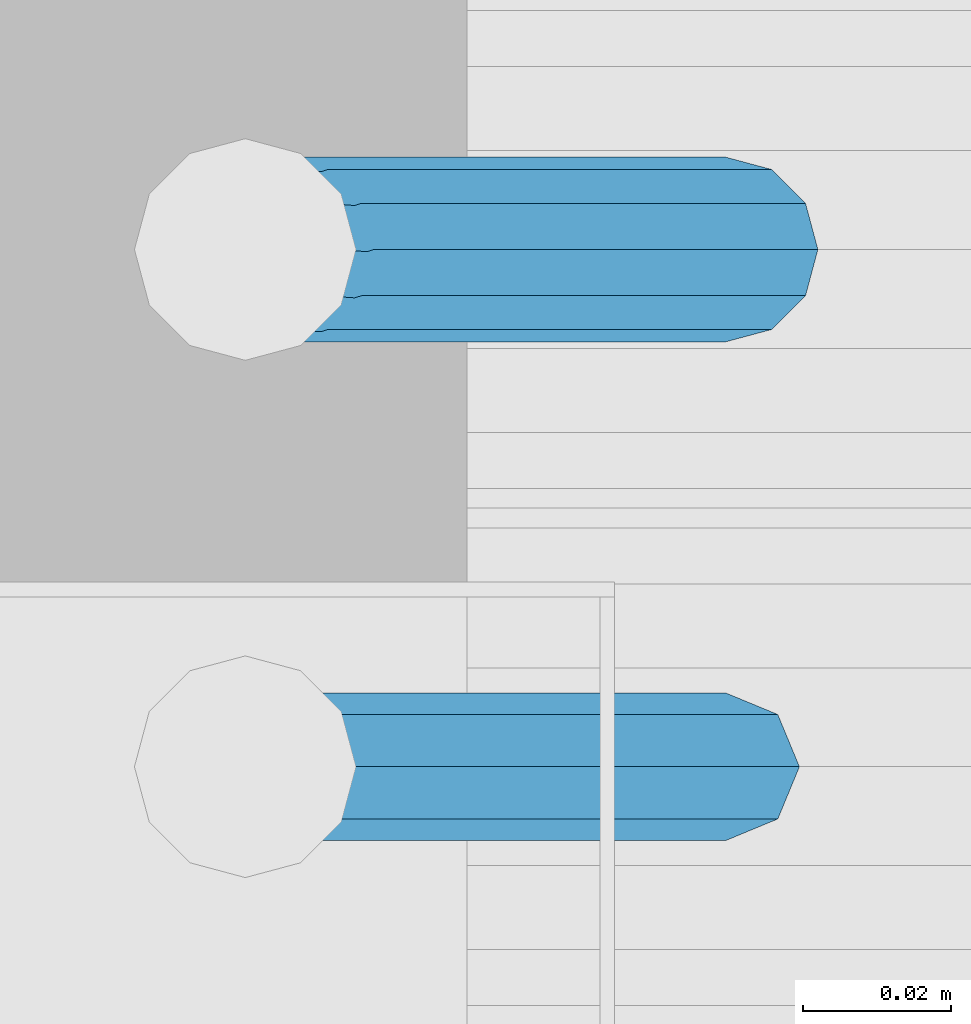
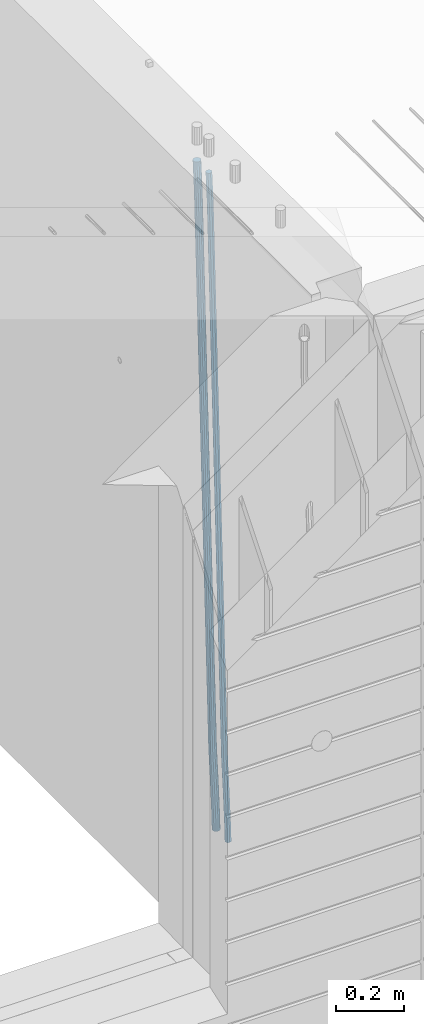
# One storey, part 102 of 349: 2 beams, 1 element without a shape of its own.
"""IFC2X3 building model written with IfcOpenShell, lengths in millimetres."""

from ifc_helpers import new_model, si_unit, frame, origin_with_axes, place, context, subcontext, project, spatial, faceted_brep, material, type_object, element, aggregate, save


model = new_model("IFC2X3")

# Units and contexts
model_context = context("Model", 3, precision=1e-05, world=origin_with_axes())
body_context = subcontext(model_context, "Body", "Model", "MODEL_VIEW")
ifc_project = project(units=[si_unit("LENGTHUNIT", "METRE", prefix="MILLI"), si_unit("AREAUNIT", "SQUARE_METRE"), si_unit("VOLUMEUNIT", "CUBIC_METRE"), si_unit("MASSUNIT", "GRAM", prefix="KILO"), si_unit("TIMEUNIT", "SECOND"), si_unit("PLANEANGLEUNIT", "RADIAN"), si_unit("SOLIDANGLEUNIT", "STERADIAN"), si_unit("THERMODYNAMICTEMPERATUREUNIT", "DEGREE_CELSIUS"), si_unit("LUMINOUSINTENSITYUNIT", "LUMEN")], contexts=[model_context])

# Site, building, storey
site_placement = place(None, origin_with_axes())
site = spatial("IfcSite", under=ifc_project, at=site_placement, CompositionType="ELEMENT")
building_placement = place(site_placement, origin_with_axes())
building = spatial("IfcBuilding", under=site, at=building_placement, CompositionType="ELEMENT")
storey_placement = place(building_placement, origin_with_axes())
storey = spatial("IfcBuildingStorey", under=building, at=storey_placement, Name="4", CompositionType="ELEMENT", Elevation=0.0)

# Assembly, beams
assembly_placement = place(storey_placement, origin_with_axes())
assembly = element("IfcElementAssembly", 1, at=assembly_placement, inside=storey, AssemblyPlace="NOTDEFINED", PredefinedType="REINFORCEMENT_UNIT")
ifc_material = material()
beam_type_1 = type_object("IfcBeamType", Name="D20", PredefinedType="NOTDEFINED")
beam_1_placement = place(assembly_placement, frame((21875.0000022791, 8805.00000000393, 90990.0), z_axis=(-0.999642804636942, -0.000205726999925762, -0.0267249099902983), x_axis=(-0.0267249099948371, 4.30000201934385e-08, 0.999642825806181)))
beam_1 = element("IfcBeam", 2, at=beam_1_placement, type_object=beam_type_1, material=ifc_material, Name="JM20", ObjectType="D20", context=body_context, shape_type="Brep", body=[
    faceted_brep([(0.0, -10.0, 0.0), (-4.19531716033816e-08, -7.07106781186667, -7.07106781187031), (60.4266690400545, -7.0710677960451, -7.07106780570757), (60.4266690441291, -9.99999998418934, 6.15546014159918e-09), (0.0, 0.0, -10.0), (60.426669036824, 1.58106558956206e-08, -9.99999999384454), (4.196772351861e-08, 7.07106781186303, -7.07106781186667), (60.4266690363438, 7.07106782768096, -7.07106780570757), (0.0, 10.0, 0.0), (60.4266690388904, 10.0000000158179, 6.15182216279209e-09), (4.196772351861e-08, 7.07106781185939, 7.07106781185939), (60.4266690429649, 7.07106782768096, 7.07106781802577), (0.0, 0.0, 10.0), (60.4266690461809, 1.58179318532348e-08, 10.0000000061555), (-4.19531716033816e-08, -7.07106781187031, 7.07106781185939), (60.4266690466611, -7.07106779605238, 7.07106781802213), (61.0378400410118, -7.07106779588503, -7.07106780564936), (60.991799419251, -9.99999998403655, 6.21366780251265e-09), (61.0569027789461, 1.5985278878361e-08, -9.99999999378269), (61.0378209396877, 7.07106782784831, -7.07106780564936), (60.9917724058905, 10.0000000159635, 6.21366780251265e-09), (60.9457317841297, 7.07106782781193, 7.0710678180767), (60.9266690461809, 1.59488990902901e-08, 10.0000000062028), (60.9457508854539, -7.07106779591413, 7.0710678180767), (61.6489592143771, -7.07106614513759, -7.06310863441468), (61.5568818710308, -9.9999984576425, 0.00735959856683621), (61.6870830769039, 1.71821739058942e-06, -9.99179257185824), (61.6489210170112, 7.07106947854481, -7.06310888312146), (61.556827851804, 10.0000015422847, 0.00735924683976918), (61.4647505084577, 7.07106922979438, 7.07782747982128), (61.4266266459163, 1.36643211590126e-06, 10.0065114172685), (61.464788705809, -7.07106639389531, 7.07782772852806), (176.543135720174, -7.07075579406956, -5.56673531796696), (176.451058376813, -9.99968810657447, 1.50373291501455), (176.581259582701, 0.000312069292704109, -8.49541925541052), (176.543097522794, 7.07137982961285, -5.56673556667374), (176.451004357587, 10.00031189336, 1.50373256329476), (176.35892701424, 7.07137958085514, 8.57420079627263), (176.320803151699, 0.000311717507429421, 11.5028847337162), (176.358965211621, -7.07075604281999, 8.57420104497578), (177.098753836006, -7.07075429323595, -5.55949898843028), (176.98362511232, -9.99968666800123, 1.510669025065), (177.146421932586, 0.000313595905026887, -8.48805862247536), (177.098706077581, 7.07138133041735, -5.55949936166144), (176.983557571715, 10.0003133318824, 1.51066849724157), (176.868428848029, 7.07138095712435, 8.58083651073321), (176.820760751449, 0.000313067976094317, 11.5093961447819), (176.868476606425, -7.07075466652896, 8.58083688396073), (177.654312950661, -7.07075204110879, -5.54863964998367), (177.516135294456, -9.99968450931192, 1.52107783331303), (177.711524267797, 0.000315886711177882, -8.47701274570863), (177.654255632195, 7.07138358250813, -5.54864021007961), (177.516054233929, 10.0003154905207, 1.5210770412159), (177.377876577739, 7.0713830223176, 8.59079452451624), (177.320665260588, 0.000315094497636892, 11.5191676202448), (177.377933896176, -7.07075260129932, 8.59079508461218), (299.499456785634, -7.07025810522464, -3.16697112782276), (299.361279129444, -9.99919057342777, 3.90274635547394), (299.556668102785, 0.000809822595329024, -6.09534422354773), (299.499399467197, 7.07187751838501, -3.1669716879187), (299.361198068917, 10.0008094264049, 3.90274556338045), (299.223020412712, 7.07187695819448, 10.9724630466735), (299.165809095575, 0.000809030381788034, 13.9008361423985), (299.223077731163, -7.07025866542244, 10.9724636067695), (300.03174732349, -7.07025594743027, -3.15656661289177), (299.971788958996, -9.99918809853989, 3.91467979818117), (300.056572611924, 0.000811849109595641, -6.08557274808481), (300.031722507032, 7.07187967631762, -3.15656653768019), (299.971753863239, 10.0008119014747, 3.91467990454839), (299.91179549876, 7.07187975035777, 10.9859263156177), (299.886970210311, 0.000811953817901667, 13.9149324508144), (299.911820315203, -7.0702558733974, 10.9859262404061), (300.564137759997, -7.07025623699155, -3.15794273276697), (300.582413367199, -9.99918843065097, 3.91310145956595), (300.556570941641, 0.000811577163403854, -6.0868651410201), (300.564145451674, 7.07187938674906, -3.15794274158179), (300.582424244858, 10.0008115693345, 3.91310144710224), (300.600699852032, 7.07187937566778, 10.9841456394352), (300.608266670402, 0.000811561512819026, 13.9130680476919), (300.600692160384, -7.07025624805829, 10.98414564825), (2294.16589219622, -7.0713405251372, -8.31099358700158), (2294.1841678034, -10.0002727187966, -1.23994939466866), (2294.15832537785, -0.000272710982244462, -11.2399159952547), (2294.16589988787, 7.07079509858886, -8.31099359582004), (2294.18417868105, 9.99972728118883, -1.23994940713601), (2294.20245428824, 7.07079508752213, 5.83109478519327), (2294.2100211066, -0.00027272663282929, 8.76001719345368), (2294.20244659658, -7.07134053620393, 5.83109479401173), (2294.7782683276, -7.07134085819416, -8.31257645345977), (2294.72126025338, -10.000273010919, -1.24133766827799), (2294.84007459224, -0.000273081772320438, -11.2416781768807), (2294.87047377572, 7.07079471537872, -8.31281477453012), (2294.85165844864, 9.9997269181622, -1.24167470516841), (2294.7946503744, 7.07079476544459, 5.82956408001337), (2294.73284410976, -0.000273010977252852, 8.75866580342336), (2294.7024449263, -7.07134080815013, 5.82980240107645), (2295.39054023061, -7.0793250091956, -8.30442771922026), (2295.25826128852, -10.0072756143927, -1.23419071494573), (2295.52170777075, -0.00916171800054144, -11.2326063125765), (2295.57492774284, 7.06160849139269, -8.30343918807193), (2295.51902460904, 9.99102432676591, -1.23279272078435), (2295.38674566693, 7.06307372157607, 5.83744428349019), (2295.25557812679, -0.0070895696117077, 8.76562287684646), (2295.20235815471, -7.07785977901949, 5.83645575234186), (2317.1947101649, -7.36365585014573, -8.01423575520312), (2317.06243122277, -10.2916064553428, -0.94399875092131), (2317.32587770502, -0.293492558957951, -10.9424143485521), (2317.37909767711, 6.77727765044983, -8.01324722405116), (2317.32319454331, 9.70669348581578, -0.942600756767206), (2317.1909156012, 6.77874288063322, 6.12763624751096), (2317.05974806109, -0.291420410569117, 9.0558148408636), (2317.00652808898, -7.36219061996962, 6.12664771636264), (2317.83015404257, -7.37194216843636, -8.00577862486898), (2317.72252095213, -10.300214160583, -0.935213608652703), (2317.90419832576, -0.301033978277701, -10.9347174723516), (2317.90127966482, 6.77046829039318, -8.00629749759901), (2317.82310777172, 9.70017451494641, -0.935947405505431), (2317.71547468127, 6.77190252279979, 6.13461761071085), (2317.64143039809, -0.29900566735887, 9.06355645819713), (2317.64434905903, -7.37050793602975, 6.13513648344451), (2318.46565174212, -7.3700661537805, -7.99751648408346), (2318.38266643914, -10.2982456018653, -0.926623872735945), (2318.48256818345, -0.299336209594912, -10.9272153854981), (2318.42350634121, 6.77200652527245, -7.99954269419686), (2318.32306384158, 9.70166538090416, -0.929489366557391), (2318.2400785386, 6.77348593281204, 6.14140324480104), (2318.22316209726, -0.297244011366274, 9.07110214621207), (2318.2822239395, -7.36858674623363, 6.1434294549108), (2418.48643733139, -7.07180401323421, -6.70013846199799), (2418.4034520284, -9.99998346132634, 0.370754149349523), (2418.5033537727, -0.00107406904135132, -9.62983736341266), (2418.44429193046, 7.07026866581873, -6.70216467211139), (2418.34384943081, 9.99992752145772, 0.367888655531715), (2418.26086412782, 7.0717480733656, 7.43878126688651), (2418.24394768651, 0.00101812917273492, 10.3684801682975), (2418.30300952874, -7.07032460568735, 7.44080747699627)], [[[0, 1, 2, 3]], [[1, 4, 5, 2]], [[4, 6, 7, 5]], [[6, 8, 9, 7]], [[8, 10, 11, 9]], [[10, 12, 13, 11]], [[12, 14, 15, 13]], [[14, 0, 3, 15]], [[14, 12, 10, 8, 6, 4, 1, 0]], [[3, 2, 16, 17]], [[2, 5, 18, 16]], [[5, 7, 19, 18]], [[7, 9, 20, 19]], [[9, 11, 21, 20]], [[11, 13, 22, 21]], [[13, 15, 23, 22]], [[15, 3, 17, 23]], [[17, 16, 24, 25]], [[16, 18, 26, 24]], [[18, 19, 27, 26]], [[19, 20, 28, 27]], [[20, 21, 29, 28]], [[21, 22, 30, 29]], [[22, 23, 31, 30]], [[23, 17, 25, 31]], [[25, 24, 32, 33]], [[24, 26, 34, 32]], [[26, 27, 35, 34]], [[27, 28, 36, 35]], [[28, 29, 37, 36]], [[29, 30, 38, 37]], [[30, 31, 39, 38]], [[31, 25, 33, 39]], [[33, 32, 40, 41]], [[32, 34, 42, 40]], [[34, 35, 43, 42]], [[35, 36, 44, 43]], [[36, 37, 45, 44]], [[37, 38, 46, 45]], [[38, 39, 47, 46]], [[39, 33, 41, 47]], [[41, 40, 48, 49]], [[40, 42, 50, 48]], [[42, 43, 51, 50]], [[43, 44, 52, 51]], [[44, 45, 53, 52]], [[45, 46, 54, 53]], [[46, 47, 55, 54]], [[47, 41, 49, 55]], [[49, 48, 56, 57]], [[48, 50, 58, 56]], [[50, 51, 59, 58]], [[51, 52, 60, 59]], [[52, 53, 61, 60]], [[53, 54, 62, 61]], [[54, 55, 63, 62]], [[55, 49, 57, 63]], [[57, 56, 64, 65]], [[56, 58, 66, 64]], [[58, 59, 67, 66]], [[59, 60, 68, 67]], [[60, 61, 69, 68]], [[61, 62, 70, 69]], [[62, 63, 71, 70]], [[63, 57, 65, 71]], [[65, 64, 72, 73]], [[64, 66, 74, 72]], [[66, 67, 75, 74]], [[67, 68, 76, 75]], [[68, 69, 77, 76]], [[69, 70, 78, 77]], [[70, 71, 79, 78]], [[71, 65, 73, 79]], [[73, 72, 80, 81]], [[72, 74, 82, 80]], [[74, 75, 83, 82]], [[75, 76, 84, 83]], [[76, 77, 85, 84]], [[77, 78, 86, 85]], [[78, 79, 87, 86]], [[79, 73, 81, 87]], [[81, 80, 88, 89]], [[80, 82, 90, 88]], [[82, 83, 91, 90]], [[83, 84, 92, 91]], [[84, 85, 93, 92]], [[85, 86, 94, 93]], [[86, 87, 95, 94]], [[87, 81, 89, 95]], [[89, 88, 96, 97]], [[88, 90, 98, 96]], [[90, 91, 99, 98]], [[91, 92, 100, 99]], [[92, 93, 101, 100]], [[93, 94, 102, 101]], [[94, 95, 103, 102]], [[95, 89, 97, 103]], [[97, 96, 104, 105]], [[96, 98, 106, 104]], [[98, 99, 107, 106]], [[99, 100, 108, 107]], [[100, 101, 109, 108]], [[101, 102, 110, 109]], [[102, 103, 111, 110]], [[103, 97, 105, 111]], [[105, 104, 112, 113]], [[104, 106, 114, 112]], [[106, 107, 115, 114]], [[107, 108, 116, 115]], [[108, 109, 117, 116]], [[109, 110, 118, 117]], [[110, 111, 119, 118]], [[111, 105, 113, 119]], [[113, 112, 120, 121]], [[112, 114, 122, 120]], [[114, 115, 123, 122]], [[115, 116, 124, 123]], [[116, 117, 125, 124]], [[117, 118, 126, 125]], [[118, 119, 127, 126]], [[119, 113, 121, 127]], [[121, 120, 128, 129]], [[120, 122, 130, 128]], [[122, 123, 131, 130]], [[123, 124, 132, 131]], [[124, 125, 133, 132]], [[125, 126, 134, 133]], [[126, 127, 135, 134]], [[127, 121, 129, 135]], [[130, 131, 132, 133, 134, 135, 129, 128]]]),
])
beam_type_2 = type_object("IfcBeamType", Name="D25", PredefinedType="NOTDEFINED")
beam_2_placement = place(assembly_placement, frame((21875.0000022791, 8875.00000000393, 90990.0), z_axis=(-0.999642804636942, -0.000205726999925762, -0.0267249099902983), x_axis=(-0.0267249099948371, 4.30000201934385e-08, 0.999642825806181)))
beam_2 = element("IfcBeam", 3, at=beam_2_placement, type_object=beam_type_2, material=ifc_material, Name="JM25", ObjectType="D25", context=body_context, shape_type="Brep", body=[
    faceted_brep([(-7.41420080885291e-08, -12.5, -3.63797880709171e-12), (-6.42030499875546e-08, -10.8253175473074, -6.25000000000364), (60.4103898235917, -10.8253175318459, -6.2499999938409), (60.4103898269532, -12.4999999845422, 6.16273609921336e-09), (-3.70782800018787e-08, -6.25000000000364, -10.8253175473074), (60.4103898202884, -6.24999998454587, -10.8253175411446), (-1.45519152283669e-11, -3.63797880709171e-12, -12.5), (60.4103898179019, 1.54577719513327e-08, -12.4999999938373), (3.70637280866504e-08, 6.25, -10.8253175473074), (60.410389817087, 6.25000001545777, -10.825317541141), (6.42030499875546e-08, 10.8253175473001, -6.25000000000364), (60.410389818062, 10.8253175627578, -6.24999999383726), (7.41420080885291e-08, 12.4999999999927, 0.0), (60.4103898205503, 12.5000000154541, 6.16273609921336e-09), (6.42176019027829e-08, 10.8253175473001, 6.24999999999636), (60.4103898238973, 10.8253175627651, 6.2500000061591), (3.70928319171071e-08, 6.24999999999636, 10.8253175473037), (60.4103898272151, 6.25000001546141, 10.8253175534664), (1.45519152283669e-11, -3.63797880709171e-12, 12.4999999999964), (60.4103898296162, 1.54541339725256e-08, 12.5000000061591), (-3.7049176171422e-08, -6.25000000000364, 10.8253175473001), (60.4103898304165, -6.24999998454587, 10.8253175534701), (-6.41884980723262e-08, -10.8253175473074, 6.25), (60.4103898294561, -10.8253175318459, 6.25000000616637), (61.0324985728803, -10.8253175316895, -6.24999999377542), (60.991802792938, -12.4999999843931, 6.22458173893392e-09), (61.0622854283865, -6.24999998437852, -10.8253175410755), (61.0731819955545, 1.5628756955266e-08, -12.4999999937718), (61.0622685480339, 6.25000001562512, -10.8253175410791), (61.032469335245, 10.8253175629216, -6.24999999377178), (60.9917690322181, 12.5000000156033, 6.22458173893392e-09), (60.9510732522613, 10.8253175629034, 6.25000000621731), (60.9212863967696, 6.25000001558874, 10.8253175535247), (60.9103898296162, 1.55814632307738e-08, 12.5000000062137), (60.9213032771368, -6.24999998441126, 10.8253175535174), (60.9511024898966, -10.8253175317113, 6.25000000621731), (61.6545545670233, -10.8253158516927, -6.24189838219536), (61.573166454793, -12.499998414296, 0.00757164385504439), (61.7141257553885, -6.24999822394238, -10.8168280205282), (61.7359179680789, 1.80548886419274e-06, -12.491368569139), (61.7140919992817, 6.25000177601396, -10.8168282403167), (61.6544960997562, 10.8253192428383, -6.2418987628771), (61.5730989426083, 12.5000015856094, 0.0075712042817031), (61.4917108303925, 10.8253190230062, 6.25704123032847), (61.4321396420273, 6.25000139525582, 10.8319708686649), (61.4103474293224, 1.36582457344048e-06, 12.5065114172721), (61.4321733981196, -6.24999860470052, 10.8319710884571), (61.4917692976451, -10.8253160715249, 6.25704161101385), (176.524302641745, -10.8250056210964, -4.74584321979273), (176.442914529529, -12.4996881836996, 1.50362680625403), (176.583873830095, -6.24968799334965, -9.3207728581292), (176.605666042786, 0.000312036081595579, -10.9953134067364), (176.583840074018, 6.25031200660669, -9.32077307791769), (176.524244174492, 10.8256294734347, -4.74584360047811), (176.44284701733, 12.5003118162058, 1.50362636668069), (176.361458905099, 10.8256292535989, 7.75309639272746), (176.301887716749, 6.25031162585219, 12.3280260310676), (176.280095504058, 0.000311596420942806, 14.0025665796711), (176.301921472827, -6.24968837410415, 12.3280262508561), (176.361517372367, -10.8250058409321, 7.75309677341284), (177.085397012124, -10.8250041057399, -4.73853556792164), (176.983633547483, -12.4996867233749, 1.51066909103247), (177.159881729676, -6.24968643771717, -9.31327097355097), (177.187129580227, 0.000313606451527448, -10.987740468332), (177.159839524218, 6.25031356221734, -9.31327130338468), (177.085323910098, 10.8256309887511, -4.73853613920801), (176.983549136537, 12.5003132764905, 1.51066843136869), (176.881785671867, 10.8256306588555, 7.7598730903228), (176.80730095433, 6.25031299082912, 12.3346084959521), (176.780053103794, 0.000312946667690994, 14.0090779907332), (176.807343159802, -6.2496870091054, 12.3346088257895), (176.881858773908, -10.8250044356355, 7.7598736616128), (177.646431799818, -10.8250018318176, -4.72756919822132), (177.524295146417, -12.4996845320202, 1.52123723245313), (177.735828462886, -6.24968410334986, -9.30201312475765), (177.768531371941, 0.00031596292683389, -10.9763759912421), (177.735777808921, 6.25031589654827, -9.30201361973741), (177.646344064575, 10.8256332626152, -4.72757005553649), (177.524193838486, 12.5003154677688, 1.52123624250817), (177.402057185071, 10.8256327675663, 7.77004267317898), (177.312660521988, 6.2503150390985, 12.3444865997226), (177.279957612933, 0.00031497282179771, 14.0188494661961), (177.312711175953, -6.24968496079964, 12.3444870946951), (177.402144920314, -10.8250023268702, 7.77004353049415), (299.455768830812, -10.8245081283076, -2.3466005802984), (299.333632177397, -12.4991908285119, 3.90220585037241), (299.545165493895, -6.24919039983797, -6.92104450684201), (299.577868402965, 0.000809666431450751, -8.59540737331918), (299.545114839959, 6.25080960005653, -6.92104500181449), (299.455681095627, 10.826126966127, -2.34660143761721), (299.333530869539, 12.5008091712825, 3.90220486042381), (299.211394216109, 10.8261264710764, 10.1510112911019), (299.12199755304, 6.25080874260857, 14.7254552176419), (299.089294643942, 0.000808676333690528, 16.399818084119), (299.122048206962, -6.24919125728957, 14.725455712618), (299.211481951279, -10.8245086233583, 10.1510121484171), (300.024791154356, -10.8245058220109, -2.33547808076037), (299.97179243555, -12.4991882411778, 3.91467976726199), (300.063582369272, -6.24918829865055, -6.91091117600809), (300.077772912133, 0.000811692589195445, -8.58563589785263), (300.063560438372, 6.250811701364, -6.91091110953494), (300.02475316888, 10.8261292726274, -2.33547796563289), (299.971750386685, 12.5008117588586, 3.91467993563856), (299.918751667865, 10.8261293380583, 10.1648377836791), (299.879960452934, 6.25081181469795, 14.7402708789268), (299.865769910102, 0.000811823456388083, 16.4149956007714), (299.879982383849, -6.2491881853166, 14.7402708124573), (299.918789653355, -10.8245057565764, 10.1648376685516), (300.593920270287, -10.8245061315029, -2.33694916256718), (300.610074274839, -12.4991885890868, 3.91302995994556), (300.582096539598, -6.24918858061756, -6.91225142858093), (300.577771241835, 0.000811420690297382, -8.58692829078791), (300.582103337059, 6.25081141938063, -6.91225143636984), (300.593932043848, 10.8261289631064, -2.33694917606044), (300.610087869776, 12.5008114109114, 3.9130299443641), (300.626241874328, 10.8261289533239, 10.1630090668841), (300.638065605017, 6.25081140244038, 14.7383113328942), (300.642390902765, 0.000811401132523315, 16.4129881951012), (300.638058807541, -6.24918859755599, 14.7383113406868), (300.626230100752, -10.8245061412817, 10.1630090803737), (2294.14353285028, -10.8255902228266, -7.48986524046995), (2294.15968685482, -12.5002726804123, -1.23988611794994), (2294.13170911958, -6.25027267194127, -12.0651675064764), (2294.12738382183, -0.000272670631602523, -13.7398443686834), (2294.13171591706, 6.24972732805691, -12.0651675142726), (2294.14354462385, 10.8250448717827, -7.48986525395958), (2294.15970044976, 12.4997273195859, -1.23988613352776), (2294.17585445431, 10.8250448620001, 5.01009298898498), (2294.187678185, 6.24972731111666, 9.58539525499873), (2294.19200348278, -0.000272690191195579, 11.2600721172021), (2294.18767138754, -6.2502726888797, 9.585395262784), (2294.17584268075, -10.8255902326073, 5.0100930024746), (2294.74938878331, -10.8255905522892, -7.49143125355113), (2294.70496048078, -12.5002729769312, -1.24129553822058), (2294.80375011452, -6.25027303739807, -12.0669045943469), (2294.85347839963, -0.00027306548145134, -13.7417211739557), (2294.88524898475, 6.24972691828589, -12.0671152424002), (2294.89054896731, 10.8250444655641, -7.49179610668216), (2294.86795822125, 12.4997269344367, -1.2417168343236), (2294.82352991869, 10.8250445097965, 5.00841888100695), (2294.76916858749, 6.24972699490354, 9.58389222179903), (2294.71944030239, -0.000272977013082709, 11.2587088014079), (2294.68766971726, -6.2502729607786, 9.58410286985236), (2294.68236973471, -10.825590508055, 5.0087837341307), (2295.35514159774, -10.8334896929118, -7.48336928222852), (2295.25014129943, -12.5073822463346, -1.23403972030064), (2295.47567672595, -6.25903509786804, -12.0579619151831), (2295.5794493938, -0.00973987576071522, -13.7320592174692), (2295.63865379873, 6.23990236538521, -12.0570881688836), (2295.63742616826, 10.8153050340698, -7.48185590923822), (2295.57609544498, 12.4904926801701, -1.23229222769442), (2295.47109514667, 10.8166001267491, 5.01703733422983), (2295.35056001844, 6.24214553170532, 9.59162996718442), (2295.24678735061, -0.00714969040200231, 11.2657272694705), (2295.18758294567, -6.2567919315461, 9.59075622088494), (2295.18881057615, -10.8321946002325, 5.01552396123952), (2317.11481405119, -11.1172402731609, -7.19376954593827), (2317.00981375287, -12.7911328265836, -0.944439984010387), (2317.23534917941, -6.54278567811707, -11.7683621788929), (2317.33912184725, -0.29349045600793, -13.4424594811753), (2317.39832625218, 5.95615178513435, -11.7674884325897), (2317.3970986217, 10.5315544538207, -7.19225617294796), (2317.33576789842, 12.2067420999228, -0.942692491407797), (2317.23076760011, 10.5328495465001, 5.30663707051644), (2317.1102324719, 5.95839495145628, 9.88122970347831), (2317.00645980405, -0.290900270651036, 11.5553270057644), (2316.94725539912, -6.54054251179696, 9.8803559571752), (2316.94848302958, -11.1159451804797, 5.30512369752978), (2317.8004851227, -11.126181564201, -7.18464394159309), (2317.70994759697, -12.80026271514, -0.935121894457552), (2317.8836082904, -6.55123910954353, -11.7597344907699), (2317.93704431444, -0.301287487300215, -13.4345017240375), (2317.94647505535, 5.94900381260777, -11.7601931137251), (2317.90937355367, 10.5248742839121, -7.18543829986083), (2317.83568112683, 12.2002231291572, -0.936039140375215), (2317.74514360113, 10.52614197822, 5.31348290676033), (2317.6620204334, 5.95119952355708, 9.88857345594079), (2317.60858440938, -0.298752098682598, 11.5633406892048), (2317.59915366847, -6.54904339859058, 9.88903207889598), (2317.63625517016, -11.124913869895, 5.31427726503171), (2318.48621414759, -11.1241535473946, -7.1757201348446), (2318.41014051515, -12.7981747344165, -0.926005966604862), (2318.53192237136, -6.54933498770879, -11.7513083179474), (2318.53501770479, -0.299537993947524, -13.426745357352), (2318.4946707558, 5.95060937655398, -11.7530992513966), (2318.42169245677, 10.5263851832951, -7.17882212257246), (2318.33563728402, 12.2017139941127, -0.929587833499681), (2318.25956365156, 10.5276928070889, 5.32012633473278), (2318.21385542781, 5.95287424740127, 9.89571451784286), (2318.21076009437, -0.296922746361815, 11.5711515572511), (2318.25110704337, -6.54707011686151, 9.89750545128845), (2318.32408534238, -11.1228459236008, 5.32322832246064), (2418.48697597762, -10.8259511810775, -5.87860183186422), (2418.41090234517, -12.4999723680994, 0.371112336375518), (2418.53268420139, -6.25113262138984, -10.454190014967), (2418.53577953482, -0.00133562762675865, -12.1296270543789), (2418.49543258583, 6.24881174287475, -10.4559809484163), (2418.4224542868, 10.8245875496141, -5.88170381958844), (2418.33639911404, 12.499916360428, 0.367530469480698), (2418.26032548158, 10.8258951734078, 6.61724463772043), (2418.21461725782, 6.25107661372022, 11.1928328208196), (2418.21152192439, 0.00127961995895021, 12.8682698602315), (2418.25186887338, -6.24886775054256, 11.1946237542688), (2418.32484717241, -10.8246435572837, 6.62034662544102)], [[[0, 1, 2, 3]], [[1, 4, 5, 2]], [[4, 6, 7, 5]], [[6, 8, 9, 7]], [[8, 10, 11, 9]], [[10, 12, 13, 11]], [[12, 14, 15, 13]], [[14, 16, 17, 15]], [[16, 18, 19, 17]], [[18, 20, 21, 19]], [[20, 22, 23, 21]], [[22, 0, 3, 23]], [[22, 20, 18, 16, 14, 12, 10, 8, 6, 4, 1, 0]], [[3, 2, 24, 25]], [[2, 5, 26, 24]], [[5, 7, 27, 26]], [[7, 9, 28, 27]], [[9, 11, 29, 28]], [[11, 13, 30, 29]], [[13, 15, 31, 30]], [[15, 17, 32, 31]], [[17, 19, 33, 32]], [[19, 21, 34, 33]], [[21, 23, 35, 34]], [[23, 3, 25, 35]], [[25, 24, 36, 37]], [[24, 26, 38, 36]], [[26, 27, 39, 38]], [[27, 28, 40, 39]], [[28, 29, 41, 40]], [[29, 30, 42, 41]], [[30, 31, 43, 42]], [[31, 32, 44, 43]], [[32, 33, 45, 44]], [[33, 34, 46, 45]], [[34, 35, 47, 46]], [[35, 25, 37, 47]], [[37, 36, 48, 49]], [[36, 38, 50, 48]], [[38, 39, 51, 50]], [[39, 40, 52, 51]], [[40, 41, 53, 52]], [[41, 42, 54, 53]], [[42, 43, 55, 54]], [[43, 44, 56, 55]], [[44, 45, 57, 56]], [[45, 46, 58, 57]], [[46, 47, 59, 58]], [[47, 37, 49, 59]], [[49, 48, 60, 61]], [[48, 50, 62, 60]], [[50, 51, 63, 62]], [[51, 52, 64, 63]], [[52, 53, 65, 64]], [[53, 54, 66, 65]], [[54, 55, 67, 66]], [[55, 56, 68, 67]], [[56, 57, 69, 68]], [[57, 58, 70, 69]], [[58, 59, 71, 70]], [[59, 49, 61, 71]], [[61, 60, 72, 73]], [[60, 62, 74, 72]], [[62, 63, 75, 74]], [[63, 64, 76, 75]], [[64, 65, 77, 76]], [[65, 66, 78, 77]], [[66, 67, 79, 78]], [[67, 68, 80, 79]], [[68, 69, 81, 80]], [[69, 70, 82, 81]], [[70, 71, 83, 82]], [[71, 61, 73, 83]], [[73, 72, 84, 85]], [[72, 74, 86, 84]], [[74, 75, 87, 86]], [[75, 76, 88, 87]], [[76, 77, 89, 88]], [[77, 78, 90, 89]], [[78, 79, 91, 90]], [[79, 80, 92, 91]], [[80, 81, 93, 92]], [[81, 82, 94, 93]], [[82, 83, 95, 94]], [[83, 73, 85, 95]], [[85, 84, 96, 97]], [[84, 86, 98, 96]], [[86, 87, 99, 98]], [[87, 88, 100, 99]], [[88, 89, 101, 100]], [[89, 90, 102, 101]], [[90, 91, 103, 102]], [[91, 92, 104, 103]], [[92, 93, 105, 104]], [[93, 94, 106, 105]], [[94, 95, 107, 106]], [[95, 85, 97, 107]], [[97, 96, 108, 109]], [[96, 98, 110, 108]], [[98, 99, 111, 110]], [[99, 100, 112, 111]], [[100, 101, 113, 112]], [[101, 102, 114, 113]], [[102, 103, 115, 114]], [[103, 104, 116, 115]], [[104, 105, 117, 116]], [[105, 106, 118, 117]], [[106, 107, 119, 118]], [[107, 97, 109, 119]], [[109, 108, 120, 121]], [[108, 110, 122, 120]], [[110, 111, 123, 122]], [[111, 112, 124, 123]], [[112, 113, 125, 124]], [[113, 114, 126, 125]], [[114, 115, 127, 126]], [[115, 116, 128, 127]], [[116, 117, 129, 128]], [[117, 118, 130, 129]], [[118, 119, 131, 130]], [[119, 109, 121, 131]], [[121, 120, 132, 133]], [[120, 122, 134, 132]], [[122, 123, 135, 134]], [[123, 124, 136, 135]], [[124, 125, 137, 136]], [[125, 126, 138, 137]], [[126, 127, 139, 138]], [[127, 128, 140, 139]], [[128, 129, 141, 140]], [[129, 130, 142, 141]], [[130, 131, 143, 142]], [[131, 121, 133, 143]], [[133, 132, 144, 145]], [[132, 134, 146, 144]], [[134, 135, 147, 146]], [[135, 136, 148, 147]], [[136, 137, 149, 148]], [[137, 138, 150, 149]], [[138, 139, 151, 150]], [[139, 140, 152, 151]], [[140, 141, 153, 152]], [[141, 142, 154, 153]], [[142, 143, 155, 154]], [[143, 133, 145, 155]], [[145, 144, 156, 157]], [[144, 146, 158, 156]], [[146, 147, 159, 158]], [[147, 148, 160, 159]], [[148, 149, 161, 160]], [[149, 150, 162, 161]], [[150, 151, 163, 162]], [[151, 152, 164, 163]], [[152, 153, 165, 164]], [[153, 154, 166, 165]], [[154, 155, 167, 166]], [[155, 145, 157, 167]], [[157, 156, 168, 169]], [[156, 158, 170, 168]], [[158, 159, 171, 170]], [[159, 160, 172, 171]], [[160, 161, 173, 172]], [[161, 162, 174, 173]], [[162, 163, 175, 174]], [[163, 164, 176, 175]], [[164, 165, 177, 176]], [[165, 166, 178, 177]], [[166, 167, 179, 178]], [[167, 157, 169, 179]], [[169, 168, 180, 181]], [[168, 170, 182, 180]], [[170, 171, 183, 182]], [[171, 172, 184, 183]], [[172, 173, 185, 184]], [[173, 174, 186, 185]], [[174, 175, 187, 186]], [[175, 176, 188, 187]], [[176, 177, 189, 188]], [[177, 178, 190, 189]], [[178, 179, 191, 190]], [[179, 169, 181, 191]], [[181, 180, 192, 193]], [[180, 182, 194, 192]], [[182, 183, 195, 194]], [[183, 184, 196, 195]], [[184, 185, 197, 196]], [[185, 186, 198, 197]], [[186, 187, 199, 198]], [[187, 188, 200, 199]], [[188, 189, 201, 200]], [[189, 190, 202, 201]], [[190, 191, 203, 202]], [[191, 181, 193, 203]], [[194, 195, 196, 197, 198, 199, 200, 201, 202, 203, 193, 192]]]),
])
aggregate(assembly, [beam_1, beam_2])

save(model, "model.ifc")
